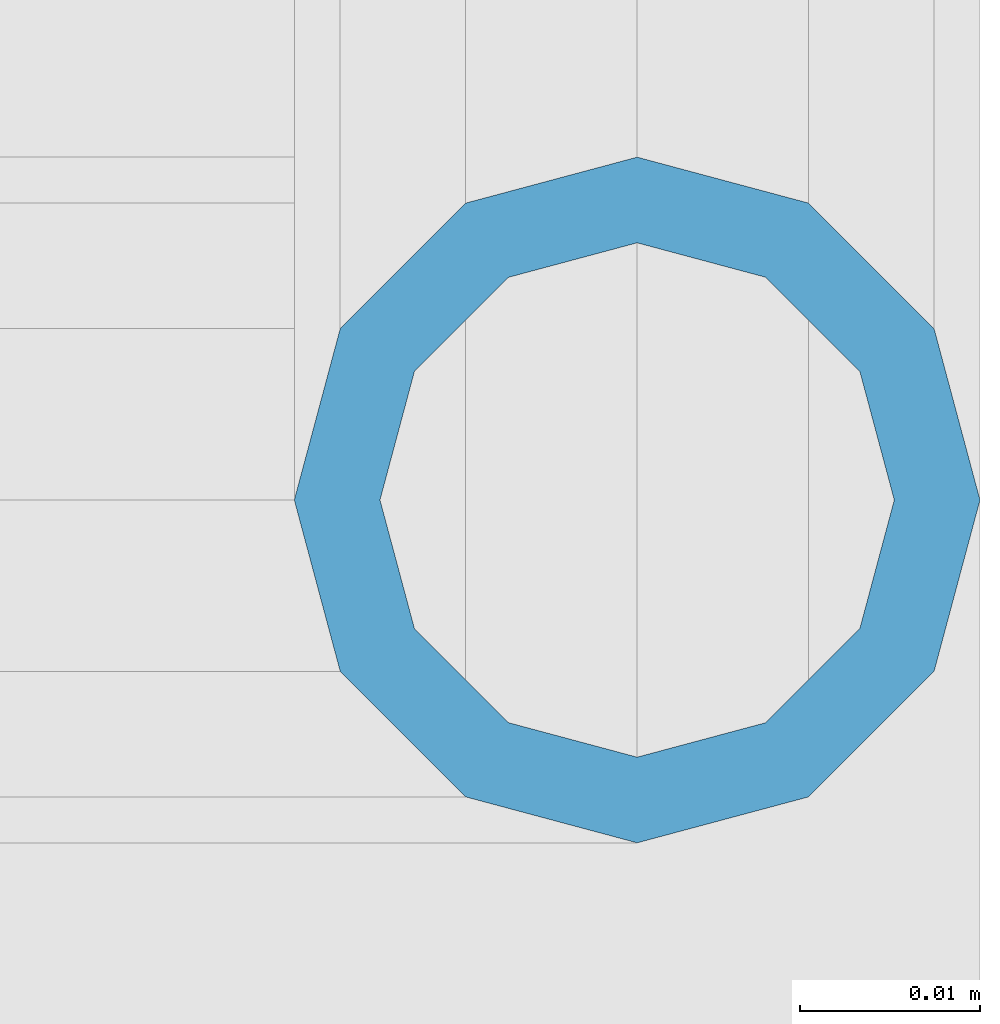
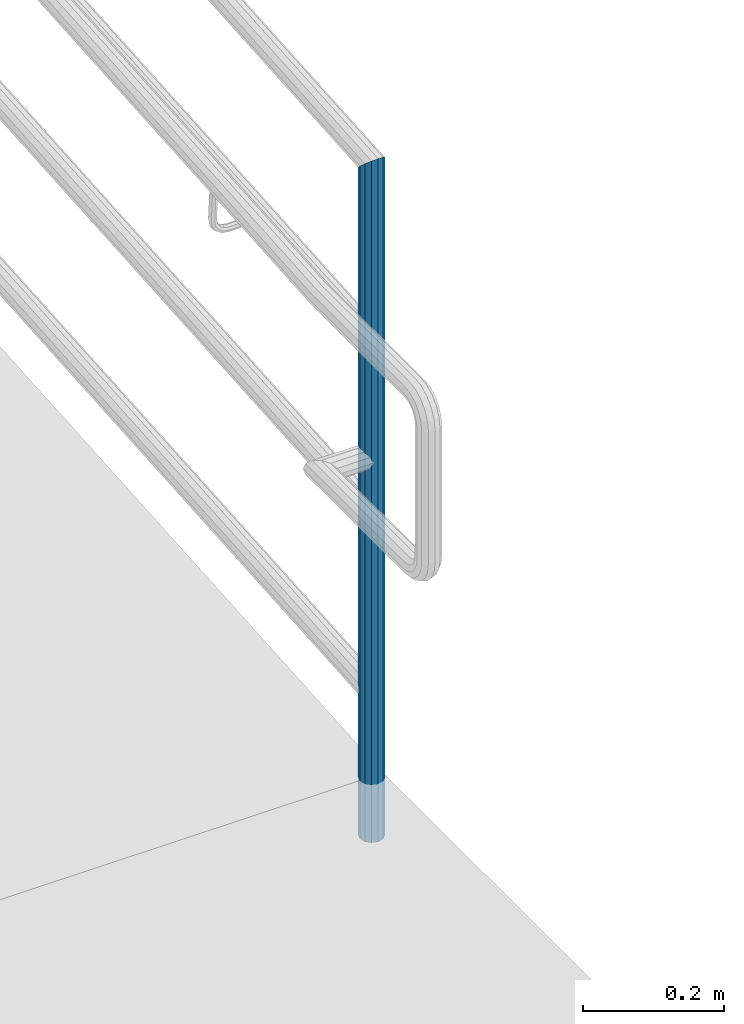
# One storey, part 655 of 1876: 1 column, 1 element without a shape of its own.
"""IFC2X3 building model written with IfcOpenShell, lengths in millimetres."""

from ifc_helpers import new_model, si_unit, frame, origin_with_axes, place, context, subcontext, project, spatial, faceted_brep, material, type_object, element, aggregate, save


model = new_model("IFC2X3")

# Units and contexts
model_context = context("Model", 3, precision=1e-05, world=origin_with_axes())
body_context = subcontext(model_context, "Body", "Model", "MODEL_VIEW")
ifc_project = project(units=[si_unit("LENGTHUNIT", "METRE", prefix="MILLI"), si_unit("AREAUNIT", "SQUARE_METRE"), si_unit("VOLUMEUNIT", "CUBIC_METRE"), si_unit("MASSUNIT", "GRAM", prefix="KILO"), si_unit("TIMEUNIT", "SECOND"), si_unit("PLANEANGLEUNIT", "RADIAN"), si_unit("SOLIDANGLEUNIT", "STERADIAN"), si_unit("THERMODYNAMICTEMPERATUREUNIT", "DEGREE_CELSIUS"), si_unit("LUMINOUSINTENSITYUNIT", "LUMEN")], contexts=[model_context])

# Site, building, storey
site_placement = place(None, origin_with_axes())
site = spatial("IfcSite", under=ifc_project, at=site_placement, CompositionType="ELEMENT")
building_placement = place(site_placement, origin_with_axes())
building = spatial("IfcBuilding", under=site, at=building_placement, Name="Undefined", CompositionType="ELEMENT")
storey_placement = place(building_placement, origin_with_axes())
storey = spatial("IfcBuildingStorey", under=building, at=storey_placement, Name="Undefined", CompositionType="ELEMENT", Elevation=0.0)

# Assembly, column
assembly_placement = place(storey_placement, origin_with_axes())
assembly = element("IfcElementAssembly", 1, at=assembly_placement, inside=storey, Name="RAIL", AssemblyPlace="NOTDEFINED", PredefinedType="RIGID_FRAME")
ifc_material = material()
column_type = type_object("IfcColumnType", PredefinedType="NOTDEFINED")
column_placement = place(assembly_placement, frame((9556.7501953125, -7620.0, -101.6), z_axis=(0.0, 1.0, 0.0), x_axis=(0.0, 0.0, 1.0)))
column = element("IfcColumn", 2, at=column_placement, type_object=column_type, material=ifc_material, Name="POST", context=body_context, shape_type="Brep", body=[
    faceted_brep([(0.0, -14.2875000000004, 0.0), (0.0, -12.373337956571, 7.14375000000018), (1161.75818255093, -12.373337956571, 7.14375000000018), (1168.40000000408, -14.2875000000004, 0.0), (0.0, -7.14374999999927, 12.3733379565701), (1156.89603472364, -7.14374999999927, 12.3733379565701), (0.0, 0.0, 14.2874999999999), (1155.1163651019, 0.0, 14.2875000000004), (0.0, 7.14374999999927, 12.3733379565701), (1156.89603472364, 7.14374999999927, 12.3733379565701), (0.0, 12.373337956571, 7.14375000000018), (1161.75818255093, 12.373337956571, 7.14375000000018), (0.0, 14.2875000000004, 0.0), (1168.40000000408, 14.2875000000004, 0.0), (0.0, 12.373337956571, -7.14375000000018), (1175.04181744898, 12.373337956571, -7.14375000000018), (0.0, 7.14374999999927, -12.3733379565701), (1179.90396527626, 7.14374999999927, -12.3733379565701), (0.0, 0.0, -14.2874999999999), (1181.683634898, 0.0, -14.2875000000004), (0.0, -7.14374999999927, -12.3733379565701), (1179.90396527626, -7.14374999999927, -12.3733379565701), (0.0, -12.373337956571, -7.14375000000018), (1175.04181744898, -12.373337956571, -7.14375000000018), (0.0, -19.0500000000002, 0.0), (0.0, -16.4977839420935, -9.52500000000146), (1177.25575659865, -16.4977839420935, -9.52499999999964), (1168.40000000408, -19.0499999999993, 0.0), (0.0, -9.52500000000009, -16.4977839420935), (1183.73862036836, -9.52499999999964, -16.4977839420935), (0.0, 0.0, -19.05), (1186.11151319735, 0.0, -19.0500000000002), (0.0, 9.52500000000009, -16.4977839420935), (1183.73862036836, 9.52499999999964, -16.4977839420935), (0.0, 16.4977839420935, -9.52500000000146), (1177.25575659865, 16.4977839420935, -9.52499999999964), (-9.09494701772928e-13, 19.05, -1.81898940354586e-12), (1168.40000000408, 19.0499999999993, 0.0), (0.0, 16.4977839420935, 9.52500000000146), (1159.54424336595, 16.4977839420935, 9.52499999999964), (0.0, 9.52500000000009, 16.4977839420935), (1153.06137959604, 9.52499999999964, 16.4977839420935), (0.0, 0.0, 19.0499999999993), (1150.68848676698, 0.0, 19.0500000000002), (0.0, -9.52500000000009, 16.4977839420935), (1153.06137959604, -9.52499999999964, 16.4977839420935), (0.0, -16.4977839420935, 9.52500000000146), (1159.54424336595, -16.4977839420935, 9.52499999999964)], [[[0, 1, 2, 3]], [[1, 4, 5, 2]], [[4, 6, 7, 5]], [[6, 8, 9, 7]], [[8, 10, 11, 9]], [[10, 12, 13, 11]], [[12, 14, 15, 13]], [[14, 16, 17, 15]], [[16, 18, 19, 17]], [[18, 20, 21, 19]], [[20, 22, 23, 21]], [[22, 0, 3, 23]], [[24, 25, 26, 27]], [[25, 28, 29, 26]], [[28, 30, 31, 29]], [[30, 32, 33, 31]], [[32, 34, 35, 33]], [[34, 36, 37, 35]], [[36, 38, 39, 37]], [[38, 40, 41, 39]], [[40, 42, 43, 41]], [[42, 44, 45, 43]], [[44, 46, 47, 45]], [[46, 24, 27, 47]], [[29, 31, 33, 35, 37, 39, 41, 43, 45, 47, 27, 26], [5, 7, 9, 11, 13, 15, 17, 19, 21, 23, 3, 2]], [[46, 44, 42, 40, 38, 36, 34, 32, 30, 28, 25, 24], [22, 20, 18, 16, 14, 12, 10, 8, 6, 4, 1, 0]]]),
])
aggregate(assembly, [column])

save(model, "model.ifc")
